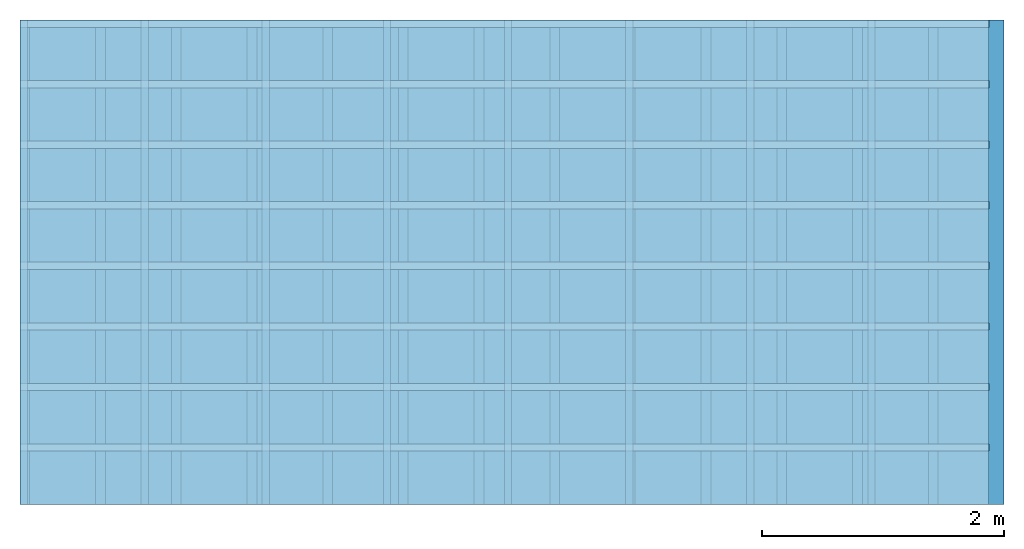
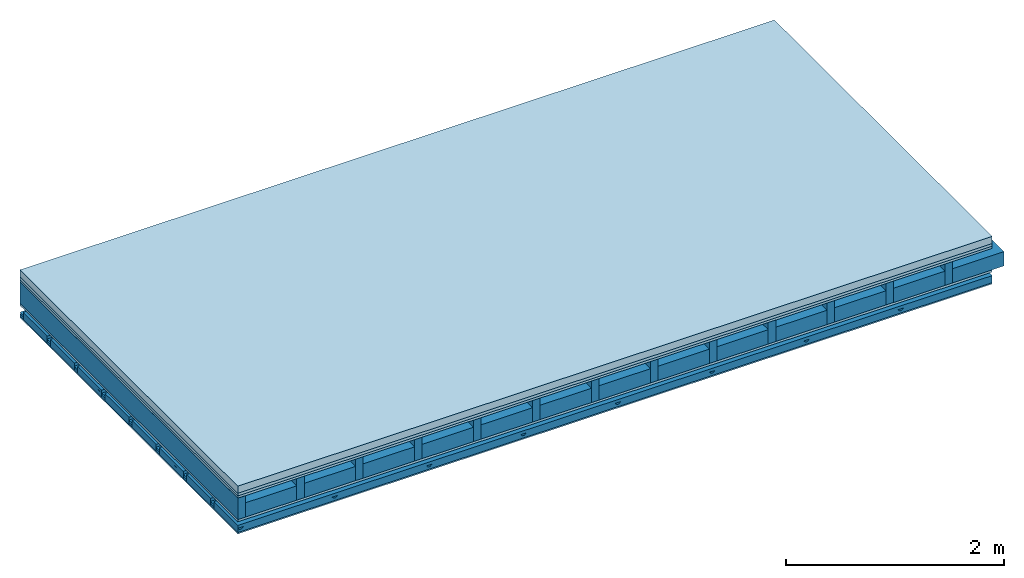
# One storey: 5 members, 5 plates, 1 element without a shape of its own.
"""IFC4 building model written with IfcOpenShell, lengths in metres."""

from ifc_helpers import new_model, si_unit, derived_unit, direction, frame, frame_2d, origin, origin_with_axes, place, context, project, spatial, polyline, rectangle, outline, extrude, material, layer, layer_set, type_object, element, aggregate, save


model = new_model("IFC4")

# Units and contexts
plan_context = context("Plan", 3, precision=1e-05, world=origin(), true_north=direction((0.0, 1.0)))
model_context = context("Model", 3, precision=1e-05, world=origin(), true_north=direction((0.0, 1.0)))
ifc_project = project(units=[si_unit("LENGTHUNIT", "METRE"), derived_unit("SOUNDPRESSUREUNIT", [(si_unit("PRESSUREUNIT", "PASCAL", prefix="MICRO"), 0)]), si_unit("ENERGYUNIT", "JOULE", prefix="MEGA"), si_unit("MASSUNIT", "GRAM", prefix="KILO"), derived_unit("THERMALTRANSMITTANCEUNIT", [(si_unit("POWERUNIT", "WATT"), 1), (si_unit("AREAUNIT", "SQUARE_METRE"), -1), (si_unit("THERMODYNAMICTEMPERATUREUNIT", "KELVIN"), -1)]), derived_unit("AREADENSITYUNIT", [(si_unit("MASSUNIT", "GRAM", prefix="KILO"), 1), (si_unit("AREAUNIT", "SQUARE_METRE"), -1)]), derived_unit("USERDEFINED", [(si_unit("ENERGYUNIT", "JOULE", prefix="MEGA"), 1), (si_unit("AREAUNIT", "SQUARE_METRE"), -1)])], contexts=[plan_context, model_context])

# Site, building, storey
site = spatial("IfcSite", under=ifc_project)
building_placement = place(None, origin())
building = spatial("IfcBuilding", under=site, at=building_placement)
storey_placement = place(building_placement, origin())
storey = spatial("IfcBuildingStorey", under=building, at=storey_placement)

# Slab, members, plates
ifc_material_1 = material(Name="Cement screed", Category="04.006")
ifc_layer_1 = layer(ifc_material_1, 0.08, Name="On-material")
ifc_material_2 = material()
ifc_layer_2 = layer(ifc_material_2, 0.03, Name="Impact sound insulation")
ifc_material_3 = material(Category="07.001")
ifc_layer_3 = layer(ifc_material_3, 0.025, Name="Sub-floor")
ifc_material_4 = material(Name="Rigid, of the art")
ifc_layer_4 = layer(ifc_material_4, 0.0, Name="Bond")
ifc_layer_5 = layer(None, 0.24, Name="Supporting structure")
ifc_layer_6 = layer(ifc_material_4, 0.0, Name="Bond")
ifc_layer_7 = layer(ifc_material_3, 0.025, Name="Lower layer 1")
ifc_layer_8 = layer(None, 0.093, Name="Coupling")
ifc_layer_9 = layer(None, 0.027, Name="Battens / profiles")
ifc_material_5 = material(Category="03.007")
ifc_layer_10 = layer(ifc_material_5, 0.015, Name="Ceiling covering 1st layer")
ifc_material_6 = material(Name="Glued joints")
ifc_layer_11 = layer(ifc_material_6, 0.0, Name="Surface / treatment")
ifc_layer_set = layer_set([ifc_layer_1, ifc_layer_2, ifc_layer_3, ifc_layer_4, ifc_layer_5, ifc_layer_6, ifc_layer_7, ifc_layer_8, ifc_layer_9, ifc_layer_10, ifc_layer_11])
slab_type = type_object("IfcSlabType", Name="A0753", PredefinedType="NOTDEFINED", material=ifc_layer_set)
slab_placement = place(None, frame((0.0, 0.0, 0.0), z_axis=(0.0, 0.0, -1.0), x_axis=(1.0, 0.0, 0.0)))
slab = element("IfcSlab", 1, at=slab_placement, inside=storey, type_object=slab_type, material=ifc_layer_set, Name="Slab #1")
ifc_material_7 = material()
member_1_placement = place(slab_placement, origin())
member_1 = element("IfcMember", 2, at=member_1_placement, material=ifc_material_7, Name="Supporting structure", context=plan_context, shape_type="SweptSolid", body=[
    extrude(rectangle(XDim=0.08, YDim=0.24, at=frame_2d((0.04, 0.12), x_axis=(1.0, 0.0))), frame((0.0, 4.0, 0.135), z_axis=(0.0, -1.0, 0.0), x_axis=(1.0, 0.0, 0.0)), (0.0, 0.0, 1.0), 4.0),
    extrude(rectangle(XDim=0.08, YDim=0.24, at=frame_2d((0.04, 0.12), x_axis=(1.0, 0.0))), frame((0.625, 4.0, 0.135), z_axis=(0.0, -1.0, 0.0), x_axis=(1.0, 0.0, 0.0)), (0.0, 0.0, 1.0), 4.0),
    extrude(rectangle(XDim=0.08, YDim=0.24, at=frame_2d((0.04, 0.12), x_axis=(1.0, 0.0))), frame((1.25, 4.0, 0.135), z_axis=(0.0, -1.0, 0.0), x_axis=(1.0, 0.0, 0.0)), (0.0, 0.0, 1.0), 4.0),
    extrude(rectangle(XDim=0.08, YDim=0.24, at=frame_2d((0.04, 0.12), x_axis=(1.0, 0.0))), frame((1.875, 4.0, 0.135), z_axis=(0.0, -1.0, 0.0), x_axis=(1.0, 0.0, 0.0)), (0.0, 0.0, 1.0), 4.0),
    extrude(rectangle(XDim=0.08, YDim=0.24, at=frame_2d((0.04, 0.12), x_axis=(1.0, 0.0))), frame((2.5, 4.0, 0.135), z_axis=(0.0, -1.0, 0.0), x_axis=(1.0, 0.0, 0.0)), (0.0, 0.0, 1.0), 4.0),
    extrude(rectangle(XDim=0.08, YDim=0.24, at=frame_2d((0.04, 0.12), x_axis=(1.0, 0.0))), frame((3.125, 4.0, 0.135), z_axis=(0.0, -1.0, 0.0), x_axis=(1.0, 0.0, 0.0)), (0.0, 0.0, 1.0), 4.0),
    extrude(rectangle(XDim=0.08, YDim=0.24, at=frame_2d((0.04, 0.12), x_axis=(1.0, 0.0))), frame((3.75, 4.0, 0.135), z_axis=(0.0, -1.0, 0.0), x_axis=(1.0, 0.0, 0.0)), (0.0, 0.0, 1.0), 4.0),
    extrude(rectangle(XDim=0.08, YDim=0.24, at=frame_2d((0.04, 0.12), x_axis=(1.0, 0.0))), frame((4.375, 4.0, 0.135), z_axis=(0.0, -1.0, 0.0), x_axis=(1.0, 0.0, 0.0)), (0.0, 0.0, 1.0), 4.0),
    extrude(rectangle(XDim=0.08, YDim=0.24, at=frame_2d((0.04, 0.12), x_axis=(1.0, 0.0))), frame((5.0, 4.0, 0.135), z_axis=(0.0, -1.0, 0.0), x_axis=(1.0, 0.0, 0.0)), (0.0, 0.0, 1.0), 4.0),
    extrude(rectangle(XDim=0.08, YDim=0.24, at=frame_2d((0.04, 0.12), x_axis=(1.0, 0.0))), frame((5.625, 4.0, 0.135), z_axis=(0.0, -1.0, 0.0), x_axis=(1.0, 0.0, 0.0)), (0.0, 0.0, 1.0), 4.0),
    extrude(rectangle(XDim=0.08, YDim=0.24, at=frame_2d((0.04, 0.12), x_axis=(1.0, 0.0))), frame((6.25, 4.0, 0.135), z_axis=(0.0, -1.0, 0.0), x_axis=(1.0, 0.0, 0.0)), (0.0, 0.0, 1.0), 4.0),
    extrude(rectangle(XDim=0.08, YDim=0.24, at=frame_2d((0.04, 0.12), x_axis=(1.0, 0.0))), frame((6.875, 4.0, 0.135), z_axis=(0.0, -1.0, 0.0), x_axis=(1.0, 0.0, 0.0)), (0.0, 0.0, 1.0), 4.0),
    extrude(rectangle(XDim=0.08, YDim=0.24, at=frame_2d((0.04, 0.12), x_axis=(1.0, 0.0))), frame((7.5, 4.0, 0.135), z_axis=(0.0, -1.0, 0.0), x_axis=(1.0, 0.0, 0.0)), (0.0, 0.0, 1.0), 4.0),
])
ifc_material_8 = material()
member_2_placement = place(slab_placement, origin())
member_2 = element("IfcMember", 3, at=member_2_placement, material=ifc_material_8, Name="in supporting structure", context=plan_context, shape_type="SweptSolid", body=[
    extrude(rectangle(XDim=0.545, YDim=0.16, at=frame_2d((0.2725, 0.08), x_axis=(1.0, 0.0))), frame((0.08, 4.0, 0.215), z_axis=(0.0, -1.0, 0.0), x_axis=(1.0, 0.0, 0.0)), (0.0, 0.0, 1.0), 4.0),
    extrude(rectangle(XDim=0.545, YDim=0.16, at=frame_2d((0.2725, 0.08), x_axis=(1.0, 0.0))), frame((0.705, 4.0, 0.215), z_axis=(0.0, -1.0, 0.0), x_axis=(1.0, 0.0, 0.0)), (0.0, 0.0, 1.0), 4.0),
    extrude(rectangle(XDim=0.545, YDim=0.16, at=frame_2d((0.2725, 0.08), x_axis=(1.0, 0.0))), frame((1.33, 4.0, 0.215), z_axis=(0.0, -1.0, 0.0), x_axis=(1.0, 0.0, 0.0)), (0.0, 0.0, 1.0), 4.0),
    extrude(rectangle(XDim=0.545, YDim=0.16, at=frame_2d((0.2725, 0.08), x_axis=(1.0, 0.0))), frame((1.955, 4.0, 0.215), z_axis=(0.0, -1.0, 0.0), x_axis=(1.0, 0.0, 0.0)), (0.0, 0.0, 1.0), 4.0),
    extrude(rectangle(XDim=0.545, YDim=0.16, at=frame_2d((0.2725, 0.08), x_axis=(1.0, 0.0))), frame((2.58, 4.0, 0.215), z_axis=(0.0, -1.0, 0.0), x_axis=(1.0, 0.0, 0.0)), (0.0, 0.0, 1.0), 4.0),
    extrude(rectangle(XDim=0.545, YDim=0.16, at=frame_2d((0.2725, 0.08), x_axis=(1.0, 0.0))), frame((3.205, 4.0, 0.215), z_axis=(0.0, -1.0, 0.0), x_axis=(1.0, 0.0, 0.0)), (0.0, 0.0, 1.0), 4.0),
    extrude(rectangle(XDim=0.545, YDim=0.16, at=frame_2d((0.2725, 0.08), x_axis=(1.0, 0.0))), frame((3.83, 4.0, 0.215), z_axis=(0.0, -1.0, 0.0), x_axis=(1.0, 0.0, 0.0)), (0.0, 0.0, 1.0), 4.0),
    extrude(rectangle(XDim=0.545, YDim=0.16, at=frame_2d((0.2725, 0.08), x_axis=(1.0, 0.0))), frame((4.455, 4.0, 0.215), z_axis=(0.0, -1.0, 0.0), x_axis=(1.0, 0.0, 0.0)), (0.0, 0.0, 1.0), 4.0),
    extrude(rectangle(XDim=0.545, YDim=0.16, at=frame_2d((0.2725, 0.08), x_axis=(1.0, 0.0))), frame((5.08, 4.0, 0.215), z_axis=(0.0, -1.0, 0.0), x_axis=(1.0, 0.0, 0.0)), (0.0, 0.0, 1.0), 4.0),
    extrude(rectangle(XDim=0.545, YDim=0.16, at=frame_2d((0.2725, 0.08), x_axis=(1.0, 0.0))), frame((5.705, 4.0, 0.215), z_axis=(0.0, -1.0, 0.0), x_axis=(1.0, 0.0, 0.0)), (0.0, 0.0, 1.0), 4.0),
    extrude(rectangle(XDim=0.545, YDim=0.16, at=frame_2d((0.2725, 0.08), x_axis=(1.0, 0.0))), frame((6.33, 4.0, 0.215), z_axis=(0.0, -1.0, 0.0), x_axis=(1.0, 0.0, 0.0)), (0.0, 0.0, 1.0), 4.0),
    extrude(rectangle(XDim=0.545, YDim=0.16, at=frame_2d((0.2725, 0.08), x_axis=(1.0, 0.0))), frame((6.955, 4.0, 0.215), z_axis=(0.0, -1.0, 0.0), x_axis=(1.0, 0.0, 0.0)), (0.0, 0.0, 1.0), 4.0),
    extrude(rectangle(XDim=0.545, YDim=0.16, at=frame_2d((0.2725, 0.08), x_axis=(1.0, 0.0))), frame((7.58, 4.0, 0.215), z_axis=(0.0, -1.0, 0.0), x_axis=(1.0, 0.0, 0.0)), (0.0, 0.0, 1.0), 4.0),
])
ifc_material_9 = material()
member_3_placement = place(slab_placement, origin())
member_3 = element("IfcMember", 4, at=member_3_placement, material=ifc_material_9, Name="Coupling", context=plan_context, shape_type="SweptSolid", body=[
    extrude(outline(polyline([(0.0, 0.0), (0.06, 0.0), (0.04, 0.02), (0.02, 0.02), (0.0, 0.0)])), frame((0.0, 4.0, 0.473), z_axis=(0.0, -1.0, 0.0), x_axis=(1.0, 0.0, 0.0)), (0.0, 0.0, 1.0), 4.0),
    extrude(outline(polyline([(0.0, 0.0), (0.06, 0.0), (0.04, 0.02), (0.02, 0.02), (0.0, 0.0)])), frame((1.0, 4.0, 0.473), z_axis=(0.0, -1.0, 0.0), x_axis=(1.0, 0.0, 0.0)), (0.0, 0.0, 1.0), 4.0),
    extrude(outline(polyline([(0.0, 0.0), (0.06, 0.0), (0.04, 0.02), (0.02, 0.02), (0.0, 0.0)])), frame((2.0, 4.0, 0.473), z_axis=(0.0, -1.0, 0.0), x_axis=(1.0, 0.0, 0.0)), (0.0, 0.0, 1.0), 4.0),
    extrude(outline(polyline([(0.0, 0.0), (0.06, 0.0), (0.04, 0.02), (0.02, 0.02), (0.0, 0.0)])), frame((3.0, 4.0, 0.473), z_axis=(0.0, -1.0, 0.0), x_axis=(1.0, 0.0, 0.0)), (0.0, 0.0, 1.0), 4.0),
    extrude(outline(polyline([(0.0, 0.0), (0.06, 0.0), (0.04, 0.02), (0.02, 0.02), (0.0, 0.0)])), frame((4.0, 4.0, 0.473), z_axis=(0.0, -1.0, 0.0), x_axis=(1.0, 0.0, 0.0)), (0.0, 0.0, 1.0), 4.0),
    extrude(outline(polyline([(0.0, 0.0), (0.06, 0.0), (0.04, 0.02), (0.02, 0.02), (0.0, 0.0)])), frame((5.0, 4.0, 0.473), z_axis=(0.0, -1.0, 0.0), x_axis=(1.0, 0.0, 0.0)), (0.0, 0.0, 1.0), 4.0),
    extrude(outline(polyline([(0.0, 0.0), (0.06, 0.0), (0.04, 0.02), (0.02, 0.02), (0.0, 0.0)])), frame((6.0, 4.0, 0.473), z_axis=(0.0, -1.0, 0.0), x_axis=(1.0, 0.0, 0.0)), (0.0, 0.0, 1.0), 4.0),
    extrude(outline(polyline([(0.0, 0.0), (0.06, 0.0), (0.04, 0.02), (0.02, 0.02), (0.0, 0.0)])), frame((7.0, 4.0, 0.473), z_axis=(0.0, -1.0, 0.0), x_axis=(1.0, 0.0, 0.0)), (0.0, 0.0, 1.0), 4.0),
])
ifc_material_10 = material()
member_4_placement = place(slab_placement, origin())
member_4 = element("IfcMember", 5, at=member_4_placement, material=ifc_material_10, Name="Battens / profiles", context=plan_context, shape_type="SweptSolid", body=[
    extrude(rectangle(XDim=0.06, YDim=0.027, at=frame_2d((0.03, 0.0135), x_axis=(1.0, 0.0))), frame((0.0, 0.0, 0.493), z_axis=(1.0, 0.0, 0.0), x_axis=(0.0, 1.0, 0.0)), (0.0, 0.0, 1.0), 8.0),
    extrude(rectangle(XDim=0.06, YDim=0.027, at=frame_2d((0.03, 0.0135), x_axis=(1.0, 0.0))), frame((0.0, 0.5, 0.493), z_axis=(1.0, 0.0, 0.0), x_axis=(0.0, 1.0, 0.0)), (0.0, 0.0, 1.0), 8.0),
    extrude(rectangle(XDim=0.06, YDim=0.027, at=frame_2d((0.03, 0.0135), x_axis=(1.0, 0.0))), frame((0.0, 1.0, 0.493), z_axis=(1.0, 0.0, 0.0), x_axis=(0.0, 1.0, 0.0)), (0.0, 0.0, 1.0), 8.0),
    extrude(rectangle(XDim=0.06, YDim=0.027, at=frame_2d((0.03, 0.0135), x_axis=(1.0, 0.0))), frame((0.0, 1.5, 0.493), z_axis=(1.0, 0.0, 0.0), x_axis=(0.0, 1.0, 0.0)), (0.0, 0.0, 1.0), 8.0),
    extrude(rectangle(XDim=0.06, YDim=0.027, at=frame_2d((0.03, 0.0135), x_axis=(1.0, 0.0))), frame((0.0, 2.0, 0.493), z_axis=(1.0, 0.0, 0.0), x_axis=(0.0, 1.0, 0.0)), (0.0, 0.0, 1.0), 8.0),
    extrude(rectangle(XDim=0.06, YDim=0.027, at=frame_2d((0.03, 0.0135), x_axis=(1.0, 0.0))), frame((0.0, 2.5, 0.493), z_axis=(1.0, 0.0, 0.0), x_axis=(0.0, 1.0, 0.0)), (0.0, 0.0, 1.0), 8.0),
    extrude(rectangle(XDim=0.06, YDim=0.027, at=frame_2d((0.03, 0.0135), x_axis=(1.0, 0.0))), frame((0.0, 3.0, 0.493), z_axis=(1.0, 0.0, 0.0), x_axis=(0.0, 1.0, 0.0)), (0.0, 0.0, 1.0), 8.0),
    extrude(rectangle(XDim=0.06, YDim=0.027, at=frame_2d((0.03, 0.0135), x_axis=(1.0, 0.0))), frame((0.0, 3.5, 0.493), z_axis=(1.0, 0.0, 0.0), x_axis=(0.0, 1.0, 0.0)), (0.0, 0.0, 1.0), 8.0),
])
ifc_material_11 = material()
member_5_placement = place(slab_placement, origin())
member_5 = element("IfcMember", 6, at=member_5_placement, material=ifc_material_11, Name="Cavity", context=plan_context, shape_type="SweptSolid", body=[
    extrude(rectangle(XDim=0.44, YDim=0.08, at=frame_2d((0.22, 0.04), x_axis=(1.0, 0.0))), frame((0.0, 0.06, 0.44), z_axis=(1.0, 0.0, 0.0), x_axis=(0.0, 1.0, 0.0)), (0.0, 0.0, 1.0), 8.0),
    extrude(rectangle(XDim=0.44, YDim=0.08, at=frame_2d((0.22, 0.04), x_axis=(1.0, 0.0))), frame((0.0, 0.56, 0.44), z_axis=(1.0, 0.0, 0.0), x_axis=(0.0, 1.0, 0.0)), (0.0, 0.0, 1.0), 8.0),
    extrude(rectangle(XDim=0.44, YDim=0.08, at=frame_2d((0.22, 0.04), x_axis=(1.0, 0.0))), frame((0.0, 1.06, 0.44), z_axis=(1.0, 0.0, 0.0), x_axis=(0.0, 1.0, 0.0)), (0.0, 0.0, 1.0), 8.0),
    extrude(rectangle(XDim=0.44, YDim=0.08, at=frame_2d((0.22, 0.04), x_axis=(1.0, 0.0))), frame((0.0, 1.56, 0.44), z_axis=(1.0, 0.0, 0.0), x_axis=(0.0, 1.0, 0.0)), (0.0, 0.0, 1.0), 8.0),
    extrude(rectangle(XDim=0.44, YDim=0.08, at=frame_2d((0.22, 0.04), x_axis=(1.0, 0.0))), frame((0.0, 2.06, 0.44), z_axis=(1.0, 0.0, 0.0), x_axis=(0.0, 1.0, 0.0)), (0.0, 0.0, 1.0), 8.0),
    extrude(rectangle(XDim=0.44, YDim=0.08, at=frame_2d((0.22, 0.04), x_axis=(1.0, 0.0))), frame((0.0, 2.56, 0.44), z_axis=(1.0, 0.0, 0.0), x_axis=(0.0, 1.0, 0.0)), (0.0, 0.0, 1.0), 8.0),
    extrude(rectangle(XDim=0.44, YDim=0.08, at=frame_2d((0.22, 0.04), x_axis=(1.0, 0.0))), frame((0.0, 3.06, 0.44), z_axis=(1.0, 0.0, 0.0), x_axis=(0.0, 1.0, 0.0)), (0.0, 0.0, 1.0), 8.0),
    extrude(rectangle(XDim=0.44, YDim=0.08, at=frame_2d((0.22, 0.04), x_axis=(1.0, 0.0))), frame((0.0, 3.56, 0.44), z_axis=(1.0, 0.0, 0.0), x_axis=(0.0, 1.0, 0.0)), (0.0, 0.0, 1.0), 8.0),
])
plate_1_placement = place(slab_placement, origin())
plate_1 = element("IfcPlate", 7, at=plate_1_placement, material=ifc_material_1, Name="On-material", context=plan_context, shape_type="SweptSolid", body=[
    extrude(rectangle(XDim=8.0, YDim=4.0, at=frame_2d((4.0, 2.0), x_axis=(1.0, 0.0))), origin_with_axes(), (0.0, 0.0, 1.0), 0.08),
])
plate_2_placement = place(slab_placement, origin())
plate_2 = element("IfcPlate", 8, at=plate_2_placement, material=ifc_material_2, Name="Impact sound insulation", context=plan_context, shape_type="SweptSolid", body=[
    extrude(rectangle(XDim=8.0, YDim=4.0, at=frame_2d((4.0, 2.0), x_axis=(1.0, 0.0))), frame((0.0, 0.0, 0.08), z_axis=(0.0, 0.0, 1.0), x_axis=(1.0, 0.0, 0.0)), (0.0, 0.0, 1.0), 0.03),
])
plate_3_placement = place(slab_placement, origin())
plate_3 = element("IfcPlate", 9, at=plate_3_placement, material=ifc_material_3, Name="Sub-floor", context=plan_context, shape_type="SweptSolid", body=[
    extrude(rectangle(XDim=8.0, YDim=4.0, at=frame_2d((4.0, 2.0), x_axis=(1.0, 0.0))), frame((0.0, 0.0, 0.11), z_axis=(0.0, 0.0, 1.0), x_axis=(1.0, 0.0, 0.0)), (0.0, 0.0, 1.0), 0.025),
])
plate_4_placement = place(slab_placement, origin())
plate_4 = element("IfcPlate", 10, at=plate_4_placement, material=ifc_material_3, Name="Lower layer 1", context=plan_context, shape_type="SweptSolid", body=[
    extrude(rectangle(XDim=8.0, YDim=4.0, at=frame_2d((4.0, 2.0), x_axis=(1.0, 0.0))), frame((0.0, 0.0, 0.375), z_axis=(0.0, 0.0, 1.0), x_axis=(1.0, 0.0, 0.0)), (0.0, 0.0, 1.0), 0.025),
])
plate_5_placement = place(slab_placement, origin())
plate_5 = element("IfcPlate", 11, at=plate_5_placement, material=ifc_material_5, Name="Ceiling covering 1st layer", context=plan_context, shape_type="SweptSolid", body=[
    extrude(rectangle(XDim=8.0, YDim=4.0, at=frame_2d((4.0, 2.0), x_axis=(1.0, 0.0))), frame((0.0, 0.0, 0.52), z_axis=(0.0, 0.0, 1.0), x_axis=(1.0, 0.0, 0.0)), (0.0, 0.0, 1.0), 0.015),
])
aggregate(slab, [plate_1, plate_2, plate_3, member_1, member_2, plate_4, member_3, member_4, member_5, plate_5])

save(model, "model.ifc")
